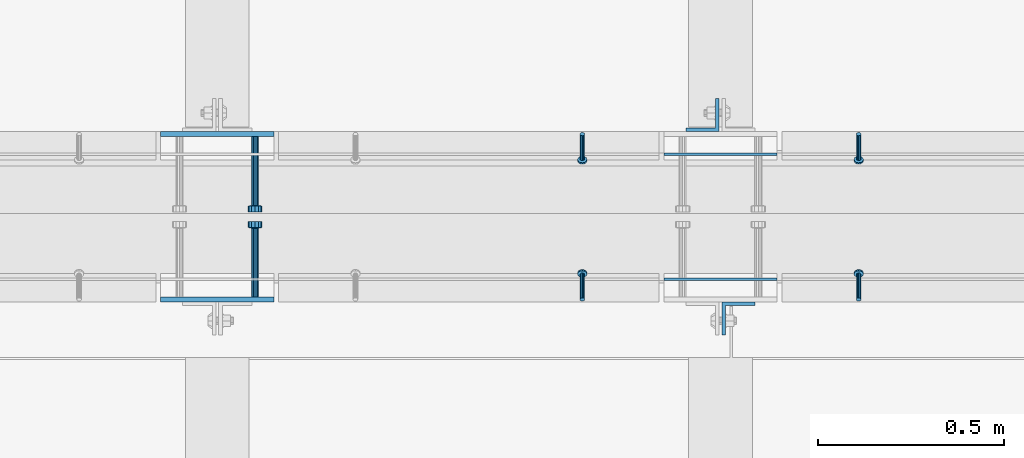
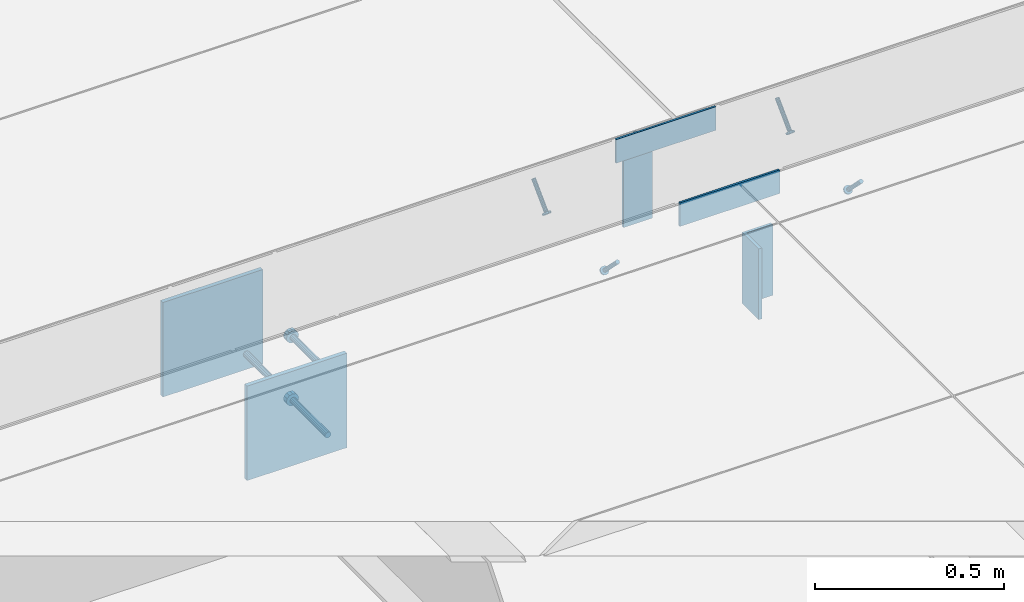
# One storey, part 2062 of 3843: 9 beams, 4 members, 10 elements without a shape of their own.
"""IFC2X3 building model written with IfcOpenShell, lengths in millimetres."""

from ifc_helpers import new_model, si_unit, frame, origin_with_axes, place, context, subcontext, project, spatial, faceted_brep, material, type_object, element, aggregate, save


model = new_model("IFC2X3")

# Units and contexts
model_context = context("Model", 3, precision=1e-05, world=origin_with_axes())
body_context = subcontext(model_context, "Body", "Model", "MODEL_VIEW")
ifc_project = project(units=[si_unit("LENGTHUNIT", "METRE", prefix="MILLI"), si_unit("AREAUNIT", "SQUARE_METRE"), si_unit("VOLUMEUNIT", "CUBIC_METRE"), si_unit("MASSUNIT", "GRAM", prefix="KILO"), si_unit("TIMEUNIT", "SECOND"), si_unit("PLANEANGLEUNIT", "RADIAN"), si_unit("SOLIDANGLEUNIT", "STERADIAN"), si_unit("THERMODYNAMICTEMPERATUREUNIT", "DEGREE_CELSIUS"), si_unit("LUMINOUSINTENSITYUNIT", "LUMEN")], contexts=[model_context])

# Site, building, storey
site_placement = place(None, origin_with_axes())
site = spatial("IfcSite", under=ifc_project, at=site_placement, CompositionType="ELEMENT")
building_placement = place(site_placement, origin_with_axes())
building = spatial("IfcBuilding", under=site, at=building_placement, Name="Undefined", CompositionType="ELEMENT")
storey_placement = place(building_placement, origin_with_axes())
storey = spatial("IfcBuildingStorey", under=building, at=storey_placement, Name="Undefined", CompositionType="ELEMENT", Elevation=0.0)

# Assembly, member
assembly_1_placement = place(storey_placement, origin_with_axes())
assembly_1 = element("IfcElementAssembly", 1, at=assembly_1_placement, inside=storey, Name="ANGLE", AssemblyPlace="NOTDEFINED", PredefinedType="RIGID_FRAME")
ifc_material_1 = material(Name="STEEL/A108")
member_type = type_object("IfcMemberType", PredefinedType="NOTDEFINED")
member_1_placement = place(assembly_1_placement, frame((47199.5772929978, 20456.5250055596, 30397.4500030518), z_axis=(1.0, 0.0, 0.0), x_axis=(0.0, -0.707106781186548, -0.707106781186548)))
member_1 = element("IfcMember", 2, at=member_1_placement, type_object=member_type, material=ifc_material_1, Name="HEADED STUD ANCHOR", context=body_context, shape_type="Brep", body=[
    faceted_brep([(7.27595761418343e-12, -3.18000006675175, 5.5), (0.0, -5.49999999998363, 3.1800000667572), (94.4879985803855, -5.50000000011278, 3.1800000667572), (94.4879985803782, -3.18000006687362, 5.5), (0.0, -6.3499999046162, 0.0), (94.4879985803855, -6.34999990474535, 0.0), (0.0, -5.49999999998363, -3.1800000667572), (94.4879985803855, -5.50000000011278, -3.1800000667572), (7.27595761418343e-12, -3.18000006675175, -5.5), (94.4879985803782, -3.18000006687362, -5.5), (7.27595761418343e-12, -1.81898940354586e-12, -6.34999990463257), (94.4879985803782, -1.20053300634027e-10, -6.34999990463257), (0.0, 3.18000006675175, -5.5), (94.4879985803709, 3.18000006663351, -5.5), (7.27595761418343e-12, 5.49999999998363, -3.1800000667572), (94.4879985803709, 5.49999999987267, -3.1800000667572), (7.27595761418343e-12, 6.3499999046162, 0.0), (94.4879985803673, 6.34999990450706, 0.0), (7.27595761418343e-12, 5.49999999998363, 3.1800000667572), (94.4879985803709, 5.49999999987267, 3.1800000667572), (0.0, 3.18000006675175, 5.5), (94.4879985803709, 3.18000006663351, 5.5), (7.27595761418343e-12, -1.81898940354586e-12, 6.34999990463257), (94.4879985803782, -1.20053300634027e-10, 6.34999990463257), (96.5199985498621, -10.9899997712273, 6.34999990463257), (96.5199985498548, -6.34000015270249, 10.9899997711182), (96.5199985498621, -12.6999998093743, 0.0), (96.5199985498621, -10.9899997712273, -6.34999990463257), (96.5199985498548, -6.34000015270249, -10.9899997711182), (96.5199985498475, -1.21872290037572e-10, -12.6899995803833), (96.5199985498402, 6.34000015245874, -10.9899997711182), (96.519998549833, 10.9899997709817, -6.34999990463257), (96.519998549833, 12.6999998091305, 0.0), (96.519998549833, 10.9899997709817, 6.34999990463257), (96.5199985498402, 6.34000015245874, 10.9899997711182), (96.5199985498475, -1.21872290037572e-10, 12.6899995803833), (101.599998473539, -10.9899997712328, 6.34999990463257), (101.599998473532, -6.34000015270976, 10.9899997711182), (101.599998473539, -12.6999998093797, 0.0), (101.599998473539, -10.9899997712328, -6.34999990463257), (101.599998473532, -6.34000015270976, -10.9899997711182), (101.599998473524, -1.29148247651756e-10, -12.6899995803833), (101.599998473517, 6.34000015245329, -10.9899997711182), (101.59999847351, 10.9899997709763, -6.34999990463257), (101.599998473503, 12.6999998091196, 0.0), (101.59999847351, 10.9899997709763, 6.34999990463257), (101.599998473517, 6.34000015245329, 10.9899997711182), (101.599998473524, -1.29148247651756e-10, 12.6899995803833)], [[[0, 1, 2, 3]], [[1, 4, 5, 2]], [[4, 6, 7, 5]], [[6, 8, 9, 7]], [[8, 10, 11, 9]], [[10, 12, 13, 11]], [[12, 14, 15, 13]], [[14, 16, 17, 15]], [[16, 18, 19, 17]], [[18, 20, 21, 19]], [[20, 22, 23, 21]], [[22, 0, 3, 23]], [[22, 20, 18, 16, 14, 12, 10, 8, 6, 4, 1, 0]], [[3, 2, 24, 25]], [[2, 5, 26, 24]], [[5, 7, 27, 26]], [[7, 9, 28, 27]], [[9, 11, 29, 28]], [[11, 13, 30, 29]], [[13, 15, 31, 30]], [[15, 17, 32, 31]], [[17, 19, 33, 32]], [[19, 21, 34, 33]], [[21, 23, 35, 34]], [[23, 3, 25, 35]], [[25, 24, 36, 37]], [[24, 26, 38, 36]], [[26, 27, 39, 38]], [[27, 28, 40, 39]], [[28, 29, 41, 40]], [[29, 30, 42, 41]], [[30, 31, 43, 42]], [[31, 32, 44, 43]], [[32, 33, 45, 44]], [[33, 34, 46, 45]], [[34, 35, 47, 46]], [[35, 25, 37, 47]], [[38, 39, 40, 41, 42, 43, 44, 45, 46, 47, 37, 36]]]),
])
aggregate(assembly_1, [member_1])

assembly_2_placement = place(storey_placement, origin_with_axes())
assembly_2 = element("IfcElementAssembly", 3, at=assembly_2_placement, inside=storey, Name="ANGLE", AssemblyPlace="NOTDEFINED", PredefinedType="RIGID_FRAME")
member_2_placement = place(assembly_2_placement, frame((46456.6272929978, 20456.5250055596, 30397.4500030518), z_axis=(1.0, 0.0, 0.0), x_axis=(0.0, -0.707106781186548, -0.707106781186548)))
member_2 = element("IfcMember", 4, at=member_2_placement, type_object=member_type, material=ifc_material_1, Name="HEADED STUD ANCHOR", context=body_context, shape_type="Brep", body=[
    faceted_brep([(7.27595761418343e-12, -3.18000006675175, 5.5), (0.0, -5.49999999998363, 3.1800000667572), (94.4879985803855, -5.50000000011278, 3.1800000667572), (94.4879985803782, -3.18000006687362, 5.5), (0.0, -6.3499999046162, 0.0), (94.4879985803855, -6.34999990474535, 0.0), (0.0, -5.49999999998363, -3.1800000667572), (94.4879985803855, -5.50000000011278, -3.1800000667572), (7.27595761418343e-12, -3.18000006675175, -5.5), (94.4879985803782, -3.18000006687362, -5.5), (7.27595761418343e-12, -1.81898940354586e-12, -6.34999990463257), (94.4879985803782, -1.20053300634027e-10, -6.34999990463257), (0.0, 3.18000006675175, -5.5), (94.4879985803709, 3.18000006663351, -5.5), (7.27595761418343e-12, 5.49999999998363, -3.1800000667572), (94.4879985803709, 5.49999999987267, -3.1800000667572), (7.27595761418343e-12, 6.3499999046162, 0.0), (94.4879985803673, 6.34999990450706, 0.0), (7.27595761418343e-12, 5.49999999998363, 3.1800000667572), (94.4879985803709, 5.49999999987267, 3.1800000667572), (0.0, 3.18000006675175, 5.5), (94.4879985803709, 3.18000006663351, 5.5), (7.27595761418343e-12, -1.81898940354586e-12, 6.34999990463257), (94.4879985803782, -1.20053300634027e-10, 6.34999990463257), (96.5199985498621, -10.9899997712273, 6.34999990463257), (96.5199985498548, -6.34000015270249, 10.9899997711182), (96.5199985498621, -12.6999998093743, 0.0), (96.5199985498621, -10.9899997712273, -6.34999990463257), (96.5199985498548, -6.34000015270249, -10.9899997711182), (96.5199985498475, -1.21872290037572e-10, -12.6899995803833), (96.5199985498402, 6.34000015245874, -10.9899997711182), (96.519998549833, 10.9899997709817, -6.34999990463257), (96.519998549833, 12.6999998091305, 0.0), (96.519998549833, 10.9899997709817, 6.34999990463257), (96.5199985498402, 6.34000015245874, 10.9899997711182), (96.5199985498475, -1.21872290037572e-10, 12.6899995803833), (101.599998473539, -10.9899997712328, 6.34999990463257), (101.599998473532, -6.34000015270976, 10.9899997711182), (101.599998473539, -12.6999998093797, 0.0), (101.599998473539, -10.9899997712328, -6.34999990463257), (101.599998473532, -6.34000015270976, -10.9899997711182), (101.599998473524, -1.29148247651756e-10, -12.6899995803833), (101.599998473517, 6.34000015245329, -10.9899997711182), (101.59999847351, 10.9899997709763, -6.34999990463257), (101.599998473503, 12.6999998091196, 0.0), (101.59999847351, 10.9899997709763, 6.34999990463257), (101.599998473517, 6.34000015245329, 10.9899997711182), (101.599998473524, -1.29148247651756e-10, 12.6899995803833)], [[[0, 1, 2, 3]], [[1, 4, 5, 2]], [[4, 6, 7, 5]], [[6, 8, 9, 7]], [[8, 10, 11, 9]], [[10, 12, 13, 11]], [[12, 14, 15, 13]], [[14, 16, 17, 15]], [[16, 18, 19, 17]], [[18, 20, 21, 19]], [[20, 22, 23, 21]], [[22, 0, 3, 23]], [[22, 20, 18, 16, 14, 12, 10, 8, 6, 4, 1, 0]], [[3, 2, 24, 25]], [[2, 5, 26, 24]], [[5, 7, 27, 26]], [[7, 9, 28, 27]], [[9, 11, 29, 28]], [[11, 13, 30, 29]], [[13, 15, 31, 30]], [[15, 17, 32, 31]], [[17, 19, 33, 32]], [[19, 21, 34, 33]], [[21, 23, 35, 34]], [[23, 3, 25, 35]], [[25, 24, 36, 37]], [[24, 26, 38, 36]], [[26, 27, 39, 38]], [[27, 28, 40, 39]], [[28, 29, 41, 40]], [[29, 30, 42, 41]], [[30, 31, 43, 42]], [[31, 32, 44, 43]], [[32, 33, 45, 44]], [[33, 34, 46, 45]], [[34, 35, 47, 46]], [[35, 25, 37, 47]], [[38, 39, 40, 41, 42, 43, 44, 45, 46, 47, 37, 36]]]),
])
aggregate(assembly_2, [member_2])

assembly_3_placement = place(storey_placement, origin_with_axes())
assembly_3 = element("IfcElementAssembly", 5, at=assembly_3_placement, inside=storey, Name="ANGLE", AssemblyPlace="NOTDEFINED", PredefinedType="RIGID_FRAME")
member_3_placement = place(assembly_3_placement, frame((47199.5402526855, 20012.0249972574, 30397.4500030518), z_axis=(-1.0, 0.0, 0.0), x_axis=(5.70000238222118e-08, 0.707106781186546, -0.707106781186546)))
member_3 = element("IfcMember", 6, at=member_3_placement, type_object=member_type, material=ifc_material_1, Name="HEADED STUD ANCHOR", context=body_context, shape_type="Brep", body=[
    faceted_brep([(7.27595761418343e-12, -3.18000006675175, 5.5), (0.0, -5.49999999998363, 3.1800000667572), (94.4879985803855, -5.50000000011278, 3.1800000667572), (94.4879985803782, -3.18000006687362, 5.5), (0.0, -6.3499999046162, 0.0), (94.4879985803855, -6.34999990474535, 0.0), (0.0, -5.49999999998363, -3.1800000667572), (94.4879985803855, -5.50000000011278, -3.1800000667572), (7.27595761418343e-12, -3.18000006675175, -5.5), (94.4879985803782, -3.18000006687362, -5.5), (7.27595761418343e-12, -1.81898940354586e-12, -6.34999990463257), (94.4879985803782, -1.20053300634027e-10, -6.34999990463257), (0.0, 3.18000006675175, -5.5), (94.4879985803709, 3.18000006663351, -5.5), (7.27595761418343e-12, 5.49999999998363, -3.1800000667572), (94.4879985803709, 5.49999999987267, -3.1800000667572), (7.27595761418343e-12, 6.3499999046162, 0.0), (94.4879985803673, 6.34999990450706, 0.0), (7.27595761418343e-12, 5.49999999998363, 3.1800000667572), (94.4879985803709, 5.49999999987267, 3.1800000667572), (0.0, 3.18000006675175, 5.5), (94.4879985803709, 3.18000006663351, 5.5), (7.27595761418343e-12, -1.81898940354586e-12, 6.34999990463257), (94.4879985803782, -1.20053300634027e-10, 6.34999990463257), (96.5199985498621, -10.9899997712273, 6.34999990463257), (96.5199985498548, -6.34000015270249, 10.9899997711182), (96.5199985498621, -12.6999998093743, 0.0), (96.5199985498621, -10.9899997712273, -6.34999990463257), (96.5199985498548, -6.34000015270249, -10.9899997711182), (96.5199985498475, -1.21872290037572e-10, -12.6899995803833), (96.5199985498402, 6.34000015245874, -10.9899997711182), (96.519998549833, 10.9899997709817, -6.34999990463257), (96.519998549833, 12.6999998091305, 0.0), (96.519998549833, 10.9899997709817, 6.34999990463257), (96.5199985498402, 6.34000015245874, 10.9899997711182), (96.5199985498475, -1.21872290037572e-10, 12.6899995803833), (101.599998473539, -10.9899997712328, 6.34999990463257), (101.599998473532, -6.34000015270976, 10.9899997711182), (101.599998473539, -12.6999998093797, 0.0), (101.599998473539, -10.9899997712328, -6.34999990463257), (101.599998473532, -6.34000015270976, -10.9899997711182), (101.599998473524, -1.29148247651756e-10, -12.6899995803833), (101.599998473517, 6.34000015245329, -10.9899997711182), (101.59999847351, 10.9899997709763, -6.34999990463257), (101.599998473503, 12.6999998091196, 0.0), (101.59999847351, 10.9899997709763, 6.34999990463257), (101.599998473517, 6.34000015245329, 10.9899997711182), (101.599998473524, -1.29148247651756e-10, 12.6899995803833)], [[[0, 1, 2, 3]], [[1, 4, 5, 2]], [[4, 6, 7, 5]], [[6, 8, 9, 7]], [[8, 10, 11, 9]], [[10, 12, 13, 11]], [[12, 14, 15, 13]], [[14, 16, 17, 15]], [[16, 18, 19, 17]], [[18, 20, 21, 19]], [[20, 22, 23, 21]], [[22, 0, 3, 23]], [[22, 20, 18, 16, 14, 12, 10, 8, 6, 4, 1, 0]], [[3, 2, 24, 25]], [[2, 5, 26, 24]], [[5, 7, 27, 26]], [[7, 9, 28, 27]], [[9, 11, 29, 28]], [[11, 13, 30, 29]], [[13, 15, 31, 30]], [[15, 17, 32, 31]], [[17, 19, 33, 32]], [[19, 21, 34, 33]], [[21, 23, 35, 34]], [[23, 3, 25, 35]], [[25, 24, 36, 37]], [[24, 26, 38, 36]], [[26, 27, 39, 38]], [[27, 28, 40, 39]], [[28, 29, 41, 40]], [[29, 30, 42, 41]], [[30, 31, 43, 42]], [[31, 32, 44, 43]], [[32, 33, 45, 44]], [[33, 34, 46, 45]], [[34, 35, 47, 46]], [[35, 25, 37, 47]], [[38, 39, 40, 41, 42, 43, 44, 45, 46, 47, 37, 36]]]),
])
aggregate(assembly_3, [member_3])

assembly_4_placement = place(storey_placement, origin_with_axes())
assembly_4 = element("IfcElementAssembly", 7, at=assembly_4_placement, inside=storey, Name="ANGLE", AssemblyPlace="NOTDEFINED", PredefinedType="RIGID_FRAME")
member_4_placement = place(assembly_4_placement, frame((46456.5902526855, 20012.0249970828, 30397.4500030518), z_axis=(-1.0, 0.0, 0.0), x_axis=(5.70000238222118e-08, 0.707106781186546, -0.707106781186546)))
member_4 = element("IfcMember", 8, at=member_4_placement, type_object=member_type, material=ifc_material_1, Name="HEADED STUD ANCHOR", context=body_context, shape_type="Brep", body=[
    faceted_brep([(7.27595761418343e-12, -3.18000006675175, 5.5), (0.0, -5.49999999998363, 3.1800000667572), (94.4879985803855, -5.50000000011278, 3.1800000667572), (94.4879985803782, -3.18000006687362, 5.5), (0.0, -6.3499999046162, 0.0), (94.4879985803855, -6.34999990474535, 0.0), (0.0, -5.49999999998363, -3.1800000667572), (94.4879985803855, -5.50000000011278, -3.1800000667572), (7.27595761418343e-12, -3.18000006675175, -5.5), (94.4879985803782, -3.18000006687362, -5.5), (7.27595761418343e-12, -1.81898940354586e-12, -6.34999990463257), (94.4879985803782, -1.20053300634027e-10, -6.34999990463257), (0.0, 3.18000006675175, -5.5), (94.4879985803709, 3.18000006663351, -5.5), (7.27595761418343e-12, 5.49999999998363, -3.1800000667572), (94.4879985803709, 5.49999999987267, -3.1800000667572), (7.27595761418343e-12, 6.3499999046162, 0.0), (94.4879985803673, 6.34999990450706, 0.0), (7.27595761418343e-12, 5.49999999998363, 3.1800000667572), (94.4879985803709, 5.49999999987267, 3.1800000667572), (0.0, 3.18000006675175, 5.5), (94.4879985803709, 3.18000006663351, 5.5), (7.27595761418343e-12, -1.81898940354586e-12, 6.34999990463257), (94.4879985803782, -1.20053300634027e-10, 6.34999990463257), (96.5199985498621, -10.9899997712273, 6.34999990463257), (96.5199985498548, -6.34000015270249, 10.9899997711182), (96.5199985498621, -12.6999998093743, 0.0), (96.5199985498621, -10.9899997712273, -6.34999990463257), (96.5199985498548, -6.34000015270249, -10.9899997711182), (96.5199985498475, -1.21872290037572e-10, -12.6899995803833), (96.5199985498402, 6.34000015245874, -10.9899997711182), (96.519998549833, 10.9899997709817, -6.34999990463257), (96.519998549833, 12.6999998091305, 0.0), (96.519998549833, 10.9899997709817, 6.34999990463257), (96.5199985498402, 6.34000015245874, 10.9899997711182), (96.5199985498475, -1.21872290037572e-10, 12.6899995803833), (101.599998473539, -10.9899997712328, 6.34999990463257), (101.599998473532, -6.34000015270976, 10.9899997711182), (101.599998473539, -12.6999998093797, 0.0), (101.599998473539, -10.9899997712328, -6.34999990463257), (101.599998473532, -6.34000015270976, -10.9899997711182), (101.599998473524, -1.29148247651756e-10, -12.6899995803833), (101.599998473517, 6.34000015245329, -10.9899997711182), (101.59999847351, 10.9899997709763, -6.34999990463257), (101.599998473503, 12.6999998091196, 0.0), (101.59999847351, 10.9899997709763, 6.34999990463257), (101.599998473517, 6.34000015245329, 10.9899997711182), (101.599998473524, -1.29148247651756e-10, 12.6899995803833)], [[[0, 1, 2, 3]], [[1, 4, 5, 2]], [[4, 6, 7, 5]], [[6, 8, 9, 7]], [[8, 10, 11, 9]], [[10, 12, 13, 11]], [[12, 14, 15, 13]], [[14, 16, 17, 15]], [[16, 18, 19, 17]], [[18, 20, 21, 19]], [[20, 22, 23, 21]], [[22, 0, 3, 23]], [[22, 20, 18, 16, 14, 12, 10, 8, 6, 4, 1, 0]], [[3, 2, 24, 25]], [[2, 5, 26, 24]], [[5, 7, 27, 26]], [[7, 9, 28, 27]], [[9, 11, 29, 28]], [[11, 13, 30, 29]], [[13, 15, 31, 30]], [[15, 17, 32, 31]], [[17, 19, 33, 32]], [[19, 21, 34, 33]], [[21, 23, 35, 34]], [[23, 3, 25, 35]], [[25, 24, 36, 37]], [[24, 26, 38, 36]], [[26, 27, 39, 38]], [[27, 28, 40, 39]], [[28, 29, 41, 40]], [[29, 30, 42, 41]], [[30, 31, 43, 42]], [[31, 32, 44, 43]], [[32, 33, 45, 44]], [[33, 34, 46, 45]], [[34, 35, 47, 46]], [[35, 25, 37, 47]], [[38, 39, 40, 41, 42, 43, 44, 45, 46, 47, 37, 36]]]),
])
aggregate(assembly_4, [member_4])

# Assembly, beam
assembly_5_placement = place(storey_placement, origin_with_axes())
assembly_5 = element("IfcElementAssembly", 9, at=assembly_5_placement, inside=storey, Name="EMBED PLATE", AssemblyPlace="NOTDEFINED", PredefinedType="RIGID_FRAME")
ifc_material_2 = material(Name="STEEL/A36")
beam_type_1 = type_object("IfcBeamType", PredefinedType="NOTDEFINED")
beam_1_placement = place(assembly_5_placement, frame((46675.675, 20065.9999969482, 30441.9), z_axis=(0.0, 0.0, 1.0), x_axis=(1.0, 0.0, 0.0)))
beam_1 = element("IfcBeam", 10, at=beam_1_placement, type_object=beam_type_1, material=ifc_material_2, Name="PLATE", context=body_context, shape_type="Brep", body=[
    faceted_brep([(0.0, 3.17500000000291, -38.0999999999985), (0.0, 3.17500000000291, 38.0999999999985), (304.800000000003, 3.17499999999927, 38.0999999999985), (304.800000000003, 3.17499999999927, -38.0999999999985), (0.0, -3.17500000000291, 38.0999999999985), (304.800000000003, -3.17499999999927, 38.0999999999985), (0.0, -3.17500000000291, -38.0999999999985), (304.800000000003, -3.17499999999927, -38.0999999999985)], [[[0, 1, 2, 3]], [[1, 4, 5, 2]], [[4, 6, 7, 5]], [[6, 0, 3, 7]], [[5, 7, 3, 2]], [[6, 4, 1, 0]]]),
])
aggregate(assembly_5, [beam_1])

assembly_6_placement = place(storey_placement, origin_with_axes())
assembly_6 = element("IfcElementAssembly", 11, at=assembly_6_placement, inside=storey, Name="EMBED PLATE", AssemblyPlace="NOTDEFINED", PredefinedType="RIGID_FRAME")
beam_2_placement = place(assembly_6_placement, frame((46980.475, 20402.5500030518, 30441.9), z_axis=(0.0, 0.0, 1.0), x_axis=(-1.0, 0.0, 0.0)))
beam_2 = element("IfcBeam", 12, at=beam_2_placement, type_object=beam_type_1, material=ifc_material_2, Name="PLATE", context=body_context, shape_type="Brep", body=[
    faceted_brep([(0.0, 3.17500000000291, -38.0999999999985), (0.0, 3.17500000000291, 38.0999999999985), (304.800000000003, 3.17499999999927, 38.0999999999985), (304.800000000003, 3.17499999999927, -38.0999999999985), (0.0, -3.17500000000291, 38.0999999999985), (304.800000000003, -3.17499999999927, 38.0999999999985), (0.0, -3.17500000000291, -38.0999999999985), (304.800000000003, -3.17499999999927, -38.0999999999985)], [[[0, 1, 2, 3]], [[1, 4, 5, 2]], [[4, 6, 7, 5]], [[6, 0, 3, 7]], [[5, 7, 3, 2]], [[6, 4, 1, 0]]]),
])
aggregate(assembly_6, [beam_2])

assembly_7_placement = place(storey_placement, origin_with_axes())
assembly_7 = element("IfcElementAssembly", 13, at=assembly_7_placement, inside=storey, Name="EMBED PLATE", AssemblyPlace="NOTDEFINED", PredefinedType="RIGID_FRAME")
beam_type_2 = type_object("IfcBeamType", PredefinedType="NOTDEFINED")
beam_3_placement = place(assembly_7_placement, frame((45475.525, 20456.5250030517, 30397.45), z_axis=(-1.0, 0.0, 0.0), x_axis=(0.0, 0.0, -1.0)))
beam_3 = element("IfcBeam", 14, at=beam_3_placement, type_object=beam_type_2, material=ifc_material_2, Name="EMBED PLATE", context=body_context, shape_type="Brep", body=[
    faceted_brep([(-1.0550138540566e-10, 6.34999999999854, -152.400000000664), (1.0550138540566e-10, 6.34999999999854, 152.400000000656), (304.799999999999, 6.34999999999854, 152.400000000001), (304.799999999999, 6.34999999999854, -152.400000000001), (1.0550138540566e-10, -6.34999999999854, 152.400000000656), (304.799999999999, -6.34999999999854, 152.400000000001), (-1.0550138540566e-10, -6.34999999999854, -152.400000000664), (304.799999999999, -6.34999999999854, -152.400000000001)], [[[0, 1, 2, 3]], [[1, 4, 5, 2]], [[4, 6, 7, 5]], [[6, 0, 3, 7]], [[5, 7, 3, 2]], [[6, 4, 1, 0]]]),
])

assembly_8_placement = place(storey_placement, origin_with_axes())
assembly_8 = element("IfcElementAssembly", 15, at=assembly_8_placement, inside=storey, Name="EMBED PLATE", AssemblyPlace="NOTDEFINED", PredefinedType="RIGID_FRAME")
beam_4_placement = place(assembly_8_placement, frame((45475.525, 20012.0249969482, 30397.45), z_axis=(1.0, 0.0, 0.0), x_axis=(0.0, 0.0, -1.0)))
beam_4 = element("IfcBeam", 16, at=beam_4_placement, type_object=beam_type_2, material=ifc_material_2, Name="EMBED PLATE", context=body_context, shape_type="Brep", body=[
    faceted_brep([(-1.0550138540566e-10, 6.34999999999854, -152.400000000664), (1.0550138540566e-10, 6.34999999999854, 152.400000000656), (304.799999999999, 6.34999999999854, 152.400000000001), (304.799999999999, 6.34999999999854, -152.400000000001), (1.0550138540566e-10, -6.34999999999854, 152.400000000656), (304.799999999999, -6.34999999999854, 152.400000000001), (-1.0550138540566e-10, -6.34999999999854, -152.400000000664), (304.799999999999, -6.34999999999854, -152.400000000001)], [[[0, 1, 2, 3]], [[1, 4, 5, 2]], [[4, 6, 7, 5]], [[6, 0, 3, 7]], [[5, 7, 3, 2]], [[6, 4, 1, 0]]]),
])

assembly_9_placement = place(storey_placement, origin_with_axes())
assembly_9 = element("IfcElementAssembly", 17, at=assembly_9_placement, inside=storey, Name="BEAM", AssemblyPlace="NOTDEFINED", PredefinedType="RIGID_FRAME")
beam_type_3 = type_object("IfcBeamType", Name="L3-1/2X3-1/2X3/8", PredefinedType="NOTDEFINED")
beam_5_placement = place(assembly_9_placement, frame((46779.65625, 20507.3250030517, 30365.7), z_axis=(-1.0, 0.0, 0.0), x_axis=(0.0, 0.0, -1.0)))
beam_5 = element("IfcBeam", 18, at=beam_5_placement, type_object=beam_type_3, material=ifc_material_2, Name="ANGLE", ObjectType="L3-1/2X3-1/2X3/8", context=body_context, shape_type="Brep", body=[
    faceted_brep([(-3.63797880709171e-12, 44.4499999999971, -44.4500000000007), (-3.63797880709171e-12, 44.4499999999971, 44.4500000000007), (228.600000000006, 44.4499999999971, 44.4500000000007), (228.600000000006, 44.4499999999971, -44.4500000000007), (0.0, 34.9250000000029, 44.4500000000007), (228.600000000006, 34.9250000000029, 44.4500000000007), (0.0, 34.9250000000029, -34.9250000000029), (228.600000000006, 34.9250000000029, -34.9249999999993), (0.0, -44.4499999999971, -34.9249999999993), (228.600000000006, -44.4499999999971, -34.9249999999993), (3.63797880709171e-12, -44.4499999999971, -44.4500000000007), (228.600000000006, -44.4499999999971, -44.4500000000007)], [[[0, 1, 2, 3]], [[1, 4, 5, 2]], [[4, 6, 7, 5]], [[6, 8, 9, 7]], [[8, 10, 11, 9]], [[10, 0, 3, 11]], [[5, 7, 9, 11, 3, 2]], [[10, 8, 6, 4, 1, 0]]]),
])
aggregate(assembly_9, [beam_5])

assembly_10_placement = place(storey_placement, origin_with_axes())
assembly_10 = element("IfcElementAssembly", 19, at=assembly_10_placement, inside=storey, Name="BEAM", AssemblyPlace="NOTDEFINED", PredefinedType="RIGID_FRAME")
beam_6_placement = place(assembly_10_placement, frame((46876.49375, 19961.2249969482, 30365.7), z_axis=(1.0, 0.0, 0.0), x_axis=(0.0, 0.0, -1.0)))
beam_6 = element("IfcBeam", 20, at=beam_6_placement, type_object=beam_type_3, material=ifc_material_2, Name="ANGLE", ObjectType="L3-1/2X3-1/2X3/8", context=body_context, shape_type="Brep", body=[
    faceted_brep([(-3.63797880709171e-12, 44.4499999999971, -44.4500000000007), (-3.63797880709171e-12, 44.4499999999971, 44.4500000000007), (228.600000000006, 44.4499999999971, 44.4500000000007), (228.600000000006, 44.4499999999971, -44.4500000000007), (0.0, 34.9250000000029, 44.4500000000007), (228.600000000006, 34.9250000000029, 44.4500000000007), (0.0, 34.9250000000029, -34.9250000000029), (228.600000000006, 34.9250000000029, -34.9249999999993), (0.0, -44.4499999999971, -34.9249999999993), (228.600000000006, -44.4499999999971, -34.9249999999993), (3.63797880709171e-12, -44.4499999999971, -44.4500000000007), (228.600000000006, -44.4499999999971, -44.4500000000007)], [[[0, 1, 2, 3]], [[1, 4, 5, 2]], [[4, 6, 7, 5]], [[6, 8, 9, 7]], [[8, 10, 11, 9]], [[10, 0, 3, 11]], [[5, 7, 9, 11, 3, 2]], [[10, 8, 6, 4, 1, 0]]]),
])
aggregate(assembly_10, [beam_6])

# Beam
beam_type_4 = type_object("IfcBeamType", PredefinedType="NOTDEFINED")
beam_7_placement = place(assembly_7_placement, frame((45577.125, 20450.1750030517, 30143.45), z_axis=(1.0, 0.0, 0.0), x_axis=(0.0, -1.0, 0.0)))
beam_7 = element("IfcBeam", 21, at=beam_7_placement, type_object=beam_type_4, material=ifc_material_1, Name="HEADED STUD ANCHOR", context=body_context, shape_type="Brep", body=[
    faceted_brep([(0.0, -9.52000045776367, 0.0), (0.0, -8.25, -4.76000022888184), (184.912000000004, -8.25, -4.76000022888184), (184.912000000004, -9.52000045776367, 0.0), (0.0, -4.76000022888184, -8.25), (184.912000000004, -4.76000022888184, -8.25), (0.0, 0.0, -9.52000045776367), (184.912000000004, 0.0, -9.52000045776367), (0.0, 4.76000022888184, -8.25), (184.912000000004, 4.76000022888184, -8.25), (0.0, 8.25, -4.76000022888184), (184.912000000004, 8.25, -4.76000022888184), (0.0, 9.52000045776367, 0.0), (184.912000000004, 9.52000045776367, 0.0), (0.0, 8.25, 4.76000022888184), (184.912000000004, 8.25, 4.76000022888184), (0.0, 4.76000022888184, 8.25), (184.912000000004, 4.76000022888184, 8.25), (0.0, 0.0, 9.52000045776367), (184.912000000004, 0.0, 9.52000045776367), (0.0, -4.76000022888184, 8.25), (184.912000000004, -4.76000022888184, 8.25), (0.0, -8.25, 4.76000022888184), (184.912000000004, -8.25, 4.76000022888184), (186.944000000003, -16.5, -9.52000045776367), (186.944000000003, -19.0499992370605, 0.0), (186.944000000003, -9.52000045776367, -16.5), (186.944000000003, 0.0, -19.0499992370605), (186.944000000003, 9.52000045776367, -16.5), (186.944000000003, 16.5, -9.52000045776367), (186.944000000003, 19.0499992370605, 0.0), (186.944000000003, 16.5, 9.52000045776367), (186.944000000003, 9.52000045776367, 16.5), (186.944000000003, 0.0, 19.0499992370605), (186.944000000003, -9.52000045776367, 16.5), (186.944000000003, -16.5, 9.52000045776367), (203.199999999997, -16.5, -9.52000045776367), (203.199999999997, -19.0499992370605, 0.0), (203.199999999997, -9.52000045776367, -16.5), (203.199999999997, 0.0, -19.0499992370605), (203.199999999997, 9.52000045776367, -16.5), (203.199999999997, 16.5, -9.52000045776367), (203.199999999997, 19.0499992370605, 0.0), (203.199999999997, 16.5, 9.52000045776367), (203.199999999997, 9.52000045776367, 16.5), (203.199999999997, 0.0, 19.0499992370605), (203.199999999997, -9.52000045776367, 16.5), (203.199999999997, -16.5, 9.52000045776367)], [[[0, 1, 2, 3]], [[1, 4, 5, 2]], [[4, 6, 7, 5]], [[6, 8, 9, 7]], [[8, 10, 11, 9]], [[10, 12, 13, 11]], [[12, 14, 15, 13]], [[14, 16, 17, 15]], [[16, 18, 19, 17]], [[18, 20, 21, 19]], [[20, 22, 23, 21]], [[22, 0, 3, 23]], [[22, 20, 18, 16, 14, 12, 10, 8, 6, 4, 1, 0]], [[3, 2, 24, 25]], [[2, 5, 26, 24]], [[5, 7, 27, 26]], [[7, 9, 28, 27]], [[9, 11, 29, 28]], [[11, 13, 30, 29]], [[13, 15, 31, 30]], [[15, 17, 32, 31]], [[17, 19, 33, 32]], [[19, 21, 34, 33]], [[21, 23, 35, 34]], [[23, 3, 25, 35]], [[25, 24, 36, 37]], [[24, 26, 38, 36]], [[26, 27, 39, 38]], [[27, 28, 40, 39]], [[28, 29, 41, 40]], [[29, 30, 42, 41]], [[30, 31, 43, 42]], [[31, 32, 44, 43]], [[32, 33, 45, 44]], [[33, 34, 46, 45]], [[34, 35, 47, 46]], [[35, 25, 37, 47]], [[38, 39, 40, 41, 42, 43, 44, 45, 46, 47, 37, 36]]]),
])

aggregate(assembly_7, [beam_7, beam_3])

beam_8_placement = place(assembly_8_placement, frame((45577.125, 20018.3749969482, 30346.65), z_axis=(-1.0, 0.0, 0.0), x_axis=(0.0, 1.0, 0.0)))
beam_8 = element("IfcBeam", 22, at=beam_8_placement, type_object=beam_type_4, material=ifc_material_2, Name="PLATE", context=body_context, shape_type="Brep", body=[
    faceted_brep([(0.0, -9.52000045776367, 0.0), (0.0, -8.25, -4.76000022888184), (184.912000000004, -8.25, -4.76000022888184), (184.912000000004, -9.52000045776367, 0.0), (0.0, -4.76000022888184, -8.25), (184.912000000004, -4.76000022888184, -8.25), (0.0, 0.0, -9.52000045776367), (184.912000000004, 0.0, -9.52000045776367), (0.0, 4.76000022888184, -8.25), (184.912000000004, 4.76000022888184, -8.25), (0.0, 8.25, -4.76000022888184), (184.912000000004, 8.25, -4.76000022888184), (0.0, 9.52000045776367, 0.0), (184.912000000004, 9.52000045776367, 0.0), (0.0, 8.25, 4.76000022888184), (184.912000000004, 8.25, 4.76000022888184), (0.0, 4.76000022888184, 8.25), (184.912000000004, 4.76000022888184, 8.25), (0.0, 0.0, 9.52000045776367), (184.912000000004, 0.0, 9.52000045776367), (0.0, -4.76000022888184, 8.25), (184.912000000004, -4.76000022888184, 8.25), (0.0, -8.25, 4.76000022888184), (184.912000000004, -8.25, 4.76000022888184), (186.944000000003, -16.5, -9.52000045776367), (186.944000000003, -19.0499992370605, 0.0), (186.944000000003, -9.52000045776367, -16.5), (186.944000000003, 0.0, -19.0499992370605), (186.944000000003, 9.52000045776367, -16.5), (186.944000000003, 16.5, -9.52000045776367), (186.944000000003, 19.0499992370605, 0.0), (186.944000000003, 16.5, 9.52000045776367), (186.944000000003, 9.52000045776367, 16.5), (186.944000000003, 0.0, 19.0499992370605), (186.944000000003, -9.52000045776367, 16.5), (186.944000000003, -16.5, 9.52000045776367), (203.199999999997, -16.5, -9.52000045776367), (203.199999999997, -19.0499992370605, 0.0), (203.199999999997, -9.52000045776367, -16.5), (203.199999999997, 0.0, -19.0499992370605), (203.199999999997, 9.52000045776367, -16.5), (203.199999999997, 16.5, -9.52000045776367), (203.199999999997, 19.0499992370605, 0.0), (203.199999999997, 16.5, 9.52000045776367), (203.199999999997, 9.52000045776367, 16.5), (203.199999999997, 0.0, 19.0499992370605), (203.199999999997, -9.52000045776367, 16.5), (203.199999999997, -16.5, 9.52000045776367)], [[[0, 1, 2, 3]], [[1, 4, 5, 2]], [[4, 6, 7, 5]], [[6, 8, 9, 7]], [[8, 10, 11, 9]], [[10, 12, 13, 11]], [[12, 14, 15, 13]], [[14, 16, 17, 15]], [[16, 18, 19, 17]], [[18, 20, 21, 19]], [[20, 22, 23, 21]], [[22, 0, 3, 23]], [[22, 20, 18, 16, 14, 12, 10, 8, 6, 4, 1, 0]], [[3, 2, 24, 25]], [[2, 5, 26, 24]], [[5, 7, 27, 26]], [[7, 9, 28, 27]], [[9, 11, 29, 28]], [[11, 13, 30, 29]], [[13, 15, 31, 30]], [[15, 17, 32, 31]], [[17, 19, 33, 32]], [[19, 21, 34, 33]], [[21, 23, 35, 34]], [[23, 3, 25, 35]], [[25, 24, 36, 37]], [[24, 26, 38, 36]], [[26, 27, 39, 38]], [[27, 28, 40, 39]], [[28, 29, 41, 40]], [[29, 30, 42, 41]], [[30, 31, 43, 42]], [[31, 32, 44, 43]], [[32, 33, 45, 44]], [[33, 34, 46, 45]], [[34, 35, 47, 46]], [[35, 25, 37, 47]], [[38, 39, 40, 41, 42, 43, 44, 45, 46, 47, 37, 36]]]),
])

beam_9_placement = place(assembly_8_placement, frame((45577.125, 20018.3749969482, 30143.45), z_axis=(-1.0, 0.0, 0.0), x_axis=(0.0, 1.0, 0.0)))
beam_9 = element("IfcBeam", 23, at=beam_9_placement, type_object=beam_type_4, material=ifc_material_1, Name="HEADED STUD ANCHOR", context=body_context, shape_type="Brep", body=[
    faceted_brep([(0.0, -9.52000045776367, 0.0), (0.0, -8.25, -4.76000022888184), (184.912000000004, -8.25, -4.76000022888184), (184.912000000004, -9.52000045776367, 0.0), (0.0, -4.76000022888184, -8.25), (184.912000000004, -4.76000022888184, -8.25), (0.0, 0.0, -9.52000045776367), (184.912000000004, 0.0, -9.52000045776367), (0.0, 4.76000022888184, -8.25), (184.912000000004, 4.76000022888184, -8.25), (0.0, 8.25, -4.76000022888184), (184.912000000004, 8.25, -4.76000022888184), (0.0, 9.52000045776367, 0.0), (184.912000000004, 9.52000045776367, 0.0), (0.0, 8.25, 4.76000022888184), (184.912000000004, 8.25, 4.76000022888184), (0.0, 4.76000022888184, 8.25), (184.912000000004, 4.76000022888184, 8.25), (0.0, 0.0, 9.52000045776367), (184.912000000004, 0.0, 9.52000045776367), (0.0, -4.76000022888184, 8.25), (184.912000000004, -4.76000022888184, 8.25), (0.0, -8.25, 4.76000022888184), (184.912000000004, -8.25, 4.76000022888184), (186.944000000003, -16.5, -9.52000045776367), (186.944000000003, -19.0499992370605, 0.0), (186.944000000003, -9.52000045776367, -16.5), (186.944000000003, 0.0, -19.0499992370605), (186.944000000003, 9.52000045776367, -16.5), (186.944000000003, 16.5, -9.52000045776367), (186.944000000003, 19.0499992370605, 0.0), (186.944000000003, 16.5, 9.52000045776367), (186.944000000003, 9.52000045776367, 16.5), (186.944000000003, 0.0, 19.0499992370605), (186.944000000003, -9.52000045776367, 16.5), (186.944000000003, -16.5, 9.52000045776367), (203.199999999997, -16.5, -9.52000045776367), (203.199999999997, -19.0499992370605, 0.0), (203.199999999997, -9.52000045776367, -16.5), (203.199999999997, 0.0, -19.0499992370605), (203.199999999997, 9.52000045776367, -16.5), (203.199999999997, 16.5, -9.52000045776367), (203.199999999997, 19.0499992370605, 0.0), (203.199999999997, 16.5, 9.52000045776367), (203.199999999997, 9.52000045776367, 16.5), (203.199999999997, 0.0, 19.0499992370605), (203.199999999997, -9.52000045776367, 16.5), (203.199999999997, -16.5, 9.52000045776367)], [[[0, 1, 2, 3]], [[1, 4, 5, 2]], [[4, 6, 7, 5]], [[6, 8, 9, 7]], [[8, 10, 11, 9]], [[10, 12, 13, 11]], [[12, 14, 15, 13]], [[14, 16, 17, 15]], [[16, 18, 19, 17]], [[18, 20, 21, 19]], [[20, 22, 23, 21]], [[22, 0, 3, 23]], [[22, 20, 18, 16, 14, 12, 10, 8, 6, 4, 1, 0]], [[3, 2, 24, 25]], [[2, 5, 26, 24]], [[5, 7, 27, 26]], [[7, 9, 28, 27]], [[9, 11, 29, 28]], [[11, 13, 30, 29]], [[13, 15, 31, 30]], [[15, 17, 32, 31]], [[17, 19, 33, 32]], [[19, 21, 34, 33]], [[21, 23, 35, 34]], [[23, 3, 25, 35]], [[25, 24, 36, 37]], [[24, 26, 38, 36]], [[26, 27, 39, 38]], [[27, 28, 40, 39]], [[28, 29, 41, 40]], [[29, 30, 42, 41]], [[30, 31, 43, 42]], [[31, 32, 44, 43]], [[32, 33, 45, 44]], [[33, 34, 46, 45]], [[34, 35, 47, 46]], [[35, 25, 37, 47]], [[38, 39, 40, 41, 42, 43, 44, 45, 46, 47, 37, 36]]]),
])

aggregate(assembly_8, [beam_8, beam_9, beam_4])

save(model, "model.ifc")
